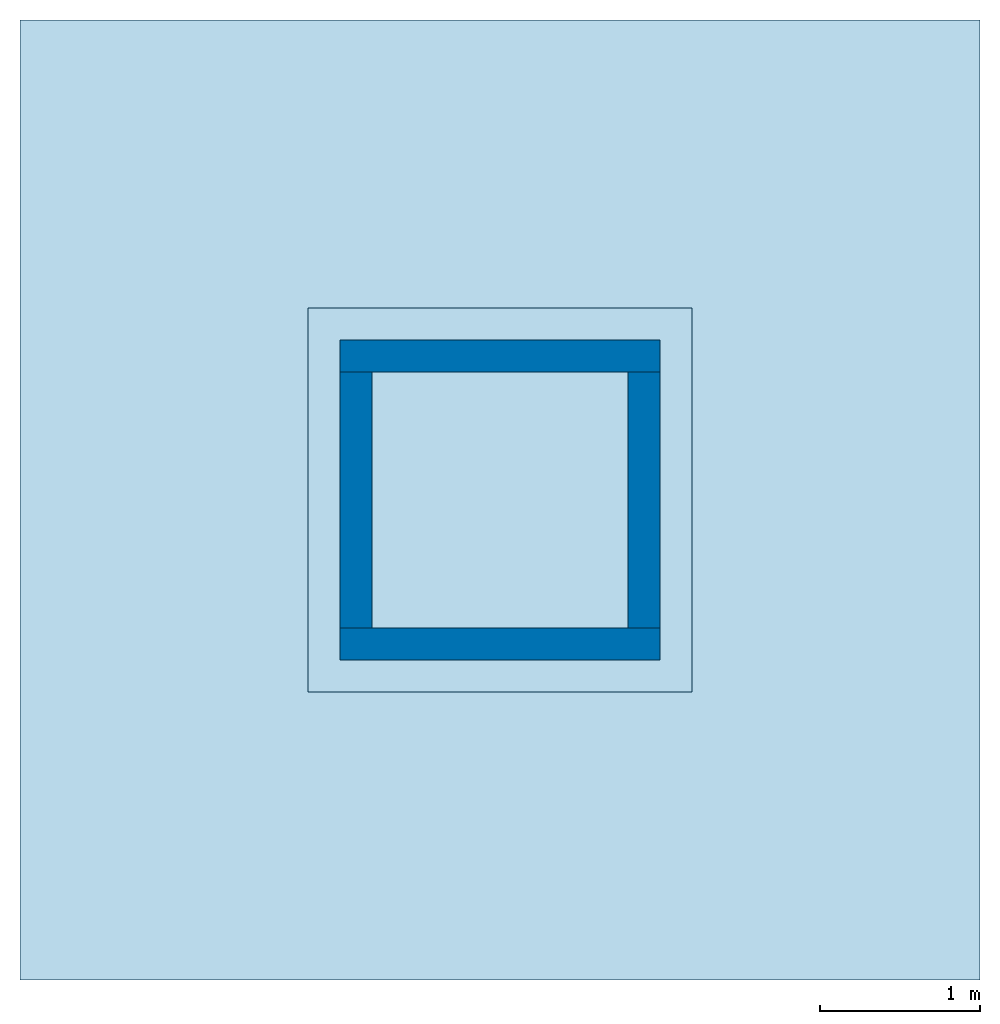
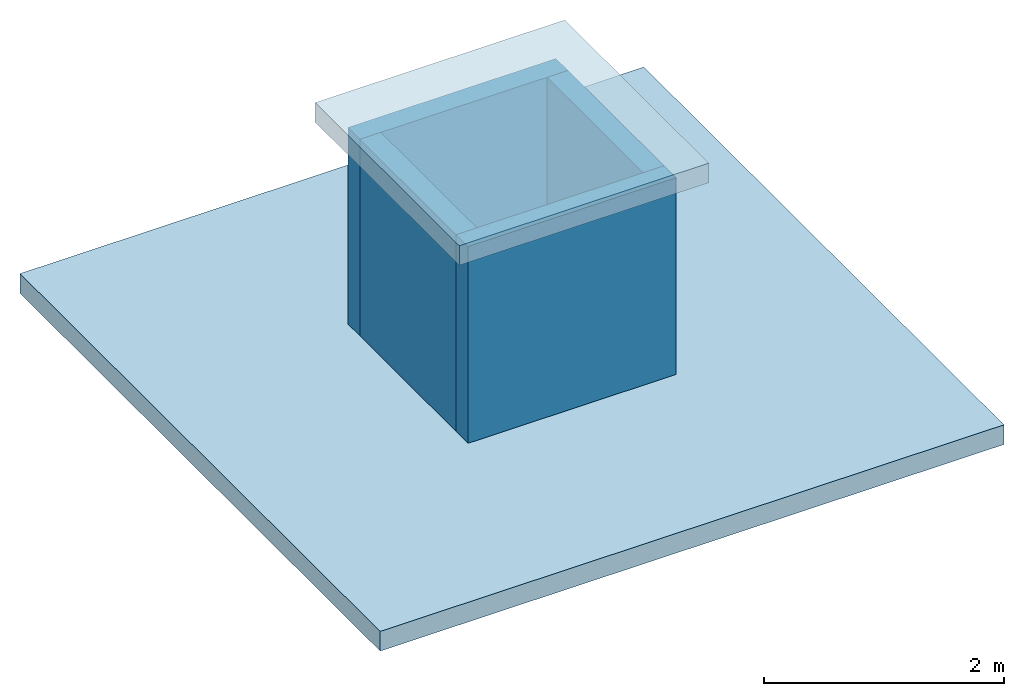
# One storey: 4 walls, 2 slabs.
"""IFC4 building model written with IfcOpenShell, lengths in metres."""

from ifc_helpers import new_model, si_unit, frame, origin_with_axes, place, context, subcontext, project, spatial, polygons, element, save


model = new_model("IFC4")

# Units and contexts
model_context = context("Model", 3, precision=1e-05, world=origin_with_axes())
plan_context = context("Plan", 2, precision=1e-05, world=origin_with_axes())
body_context = subcontext(model_context, "Body", "Model", "MODEL_VIEW")
ifc_project = project(units=[si_unit("LENGTHUNIT", "METRE"), si_unit("AREAUNIT", "SQUARE_METRE"), si_unit("VOLUMEUNIT", "CUBIC_METRE")], contexts=[model_context, plan_context])

# Site, building, storey
site_placement = place(None, origin_with_axes())
site = spatial("IfcSite", under=ifc_project, at=site_placement)
building_placement = place(site_placement, origin_with_axes())
building = spatial("IfcBuilding", under=site, at=building_placement, Name="Building")
storey_placement = place(building_placement, origin_with_axes())
storey = spatial("IfcBuildingStorey", under=building, at=storey_placement, Name="Ground Floor")

# Slabs
slab_1_placement = place(storey_placement, origin_with_axes())
element("IfcSlab", 1, at=slab_1_placement, inside=storey, Name="Slab-1", PredefinedType="BASESLAB", context=body_context, shape_type="Tessellation", body=[
    polygons([(-3.0, -3.0, 0.0), (3.0, -3.0, 0.0), (-3.0, 3.0, 0.0), (3.0, 3.0, 0.0), (-3.0, -3.0, -0.200000002980232), (3.0, -3.0, -0.200000002980232), (-3.0, 3.0, -0.200000002980232), (3.0, 3.0, -0.200000002980232)], [[[1, 2, 4, 3]], [[5, 7, 8, 6]], [[1, 3, 7, 5]], [[2, 1, 5, 6]], [[4, 2, 6, 8]], [[3, 4, 8, 7]]]),
])
slab_2_placement = place(storey_placement, frame((0.0, 0.0, 2.20000433921814), z_axis=(0.0, 0.0, 1.0), x_axis=(1.0, 0.0, 0.0)))
element("IfcSlab", 2, at=slab_2_placement, inside=storey, Name="Slab-2", PredefinedType="ROOF", context=body_context, shape_type="Tessellation", body=[
    polygons([(-1.20000004768372, -1.20000004768372, 0.0), (1.20000004768372, -1.20000004768372, 0.0), (-1.20000004768372, 1.20000004768372, 0.0), (1.20000004768372, 1.20000004768372, 0.0), (-1.20000004768372, -1.20000004768372, -0.200000002980232), (1.20000004768372, -1.20000004768372, -0.200000002980232), (-1.20000004768372, 1.20000004768372, -0.200000002980232), (1.20000004768372, 1.20000004768372, -0.200000002980232)], [[[1, 2, 4, 3]], [[5, 7, 8, 6]], [[1, 3, 7, 5]], [[2, 1, 5, 6]], [[4, 2, 6, 8]], [[3, 4, 8, 7]]]),
])

# Walls
wall_1_placement = place(storey_placement, frame((0.0, -0.800000071525574, 1.00000441074371), z_axis=(0.0, -1.0, -4.37113882867379e-08), x_axis=(1.0, 0.0, 0.0)))
element("IfcWall", 3, at=wall_1_placement, inside=storey, Name="Wall-2", PredefinedType="SOLIDWALL", context=body_context, shape_type="Tessellation", body=[
    polygons([(-1.0, -1.0, 0.200000002980232), (1.0, -1.0, 0.200000002980232), (-1.0, 1.0, 0.200000002980232), (1.0, 1.0, 0.200000002980232), (-1.0, -1.0, 0.0), (1.0, -1.0, 0.0), (-1.0, 1.0, 0.0), (1.0, 1.0, 0.0)], [[[1, 2, 4, 3]], [[5, 7, 8, 6]], [[1, 3, 7, 5]], [[2, 1, 5, 6]], [[4, 2, 6, 8]], [[3, 4, 8, 7]]]),
])
wall_2_placement = place(storey_placement, frame((0.799999952316284, -1.19209289550781e-07, 1.00000441074371), z_axis=(1.0, 4.37113882867379e-08, -4.37113882867379e-08), x_axis=(-4.37113882867379e-08, 1.0, 0.0)))
element("IfcWall", 4, at=wall_2_placement, inside=storey, Name="Wall-1", PredefinedType="SOLIDWALL", context=body_context, shape_type="Tessellation", body=[
    polygons([(-0.800000011920929, -1.0, 0.200000017881393), (0.800000309944153, -1.0, 0.199999988079071), (-0.800000011920929, 1.0, 0.200000017881393), (0.800000309944153, 1.0, 0.199999988079071), (-0.800000011920929, -1.0, 8.74227712444053e-09), (0.800000309944153, -1.0, -8.74226380176424e-09), (-0.800000011920929, 1.0, 8.74227712444053e-09), (0.800000309944153, 1.0, -8.74226380176424e-09)], [[[1, 2, 4, 3]], [[5, 7, 8, 6]], [[1, 3, 7, 5]], [[2, 1, 5, 6]], [[4, 2, 6, 8]], [[3, 4, 8, 7]]]),
])
wall_3_placement = place(storey_placement, frame((0.799999952316284, -1.19209289550781e-07, 1.00000441074371), z_axis=(1.0, 4.37113882867379e-08, -4.37113882867379e-08), x_axis=(-4.37113882867379e-08, 1.0, 0.0)))
element("IfcWall", 5, at=wall_3_placement, inside=storey, Name="Wall-3", PredefinedType="SOLIDWALL", context=body_context, shape_type="Tessellation", body=[
    polygons([(-0.799999952316284, -1.0, -1.79999995231628), (-0.799999952316284, 0.999999940395355, -1.80000007152557), (0.800000369548798, -1.0, -1.79999983310699), (-0.799999952316284, -1.0, -1.59999990463257), (-0.799999952316284, 0.999999940395355, -1.60000002384186), (0.800000369548798, -1.0, -1.59999978542328), (0.800000369548798, 0.999999940395355, -1.59999990463257), (0.800000369548798, 0.999999940395355, -1.79999995231628)], [[[2, 1, 4, 5]], [[1, 2, 8, 3]], [[1, 3, 6, 4]], [[4, 6, 7, 5]], [[3, 8, 7, 6]], [[8, 2, 5, 7]]]),
])
wall_4_placement = place(storey_placement, frame((0.0, -0.800000071525574, 1.00000441074371), z_axis=(0.0, -1.0, -4.37113882867379e-08), x_axis=(1.0, 0.0, 0.0)))
element("IfcWall", 6, at=wall_4_placement, inside=storey, Name="Wall-4", PredefinedType="SOLIDWALL", context=body_context, shape_type="Tessellation", body=[
    polygons([(-1.0, -1.0, -1.80000007152557), (-1.0, 0.999999940395355, -1.80000019073486), (1.0, -1.0, -1.80000007152557), (-1.0, -1.0, -1.60000002384186), (-1.0, 0.999999940395355, -1.60000026226044), (1.0, -1.0, -1.60000002384186), (1.0, 0.999999940395355, -1.60000026226044), (1.0, 0.999999940395355, -1.80000019073486)], [[[1, 4, 5, 2]], [[1, 2, 8, 3]], [[3, 6, 4, 1]], [[4, 6, 7, 5]], [[8, 7, 6, 3]], [[2, 5, 7, 8]]]),
])

save(model, "model.ifc")
